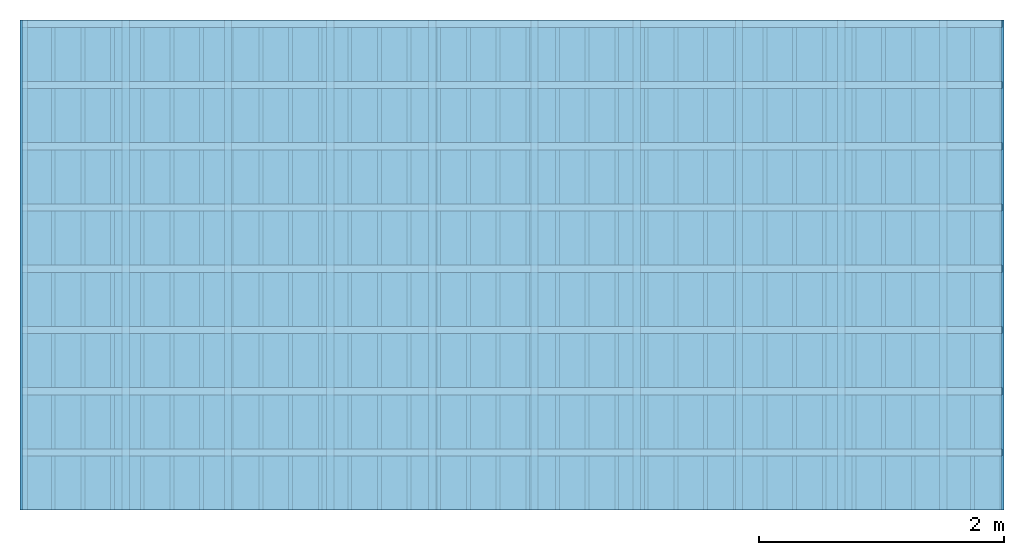
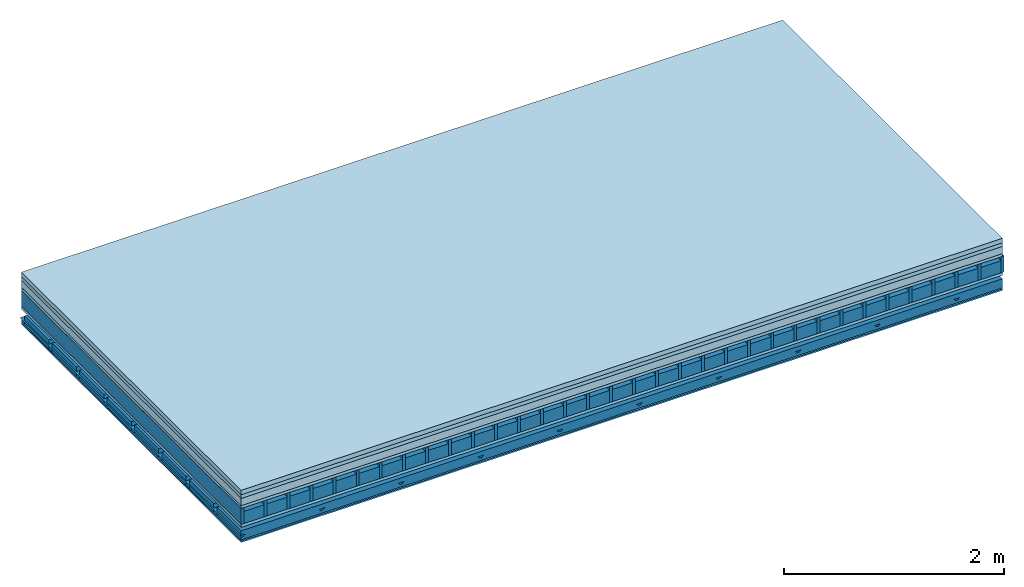
# One storey: 7 plates, 5 members, 1 element without a shape of its own.
"""IFC4 building model written with IfcOpenShell, lengths in metres."""

from ifc_helpers import new_model, si_unit, derived_unit, direction, frame, frame_2d, origin, origin_with_axes, place, context, project, spatial, polyline, rectangle, outline, extrude, material, layer, layer_set, type_object, element, aggregate, save


model = new_model("IFC4")

# Units and contexts
plan_context = context("Plan", 3, precision=1e-05, world=origin(), true_north=direction((0.0, 1.0)))
model_context = context("Model", 3, precision=1e-05, world=origin(), true_north=direction((0.0, 1.0)))
ifc_project = project(units=[si_unit("LENGTHUNIT", "METRE"), derived_unit("SOUNDPRESSUREUNIT", [(si_unit("PRESSUREUNIT", "PASCAL", prefix="MICRO"), 0)]), si_unit("ENERGYUNIT", "JOULE", prefix="MEGA"), si_unit("MASSUNIT", "GRAM", prefix="KILO"), derived_unit("THERMALTRANSMITTANCEUNIT", [(si_unit("POWERUNIT", "WATT"), 1), (si_unit("AREAUNIT", "SQUARE_METRE"), -1), (si_unit("THERMODYNAMICTEMPERATUREUNIT", "KELVIN"), -1)]), derived_unit("AREADENSITYUNIT", [(si_unit("MASSUNIT", "GRAM", prefix="KILO"), 1), (si_unit("AREAUNIT", "SQUARE_METRE"), -1)]), derived_unit("USERDEFINED", [(si_unit("ENERGYUNIT", "JOULE", prefix="MEGA"), 1), (si_unit("AREAUNIT", "SQUARE_METRE"), -1)])], contexts=[plan_context, model_context])

# Site, building, storey
site = spatial("IfcSite", under=ifc_project)
building_placement = place(None, origin())
building = spatial("IfcBuilding", under=site, at=building_placement)
storey_placement = place(building_placement, origin())
storey = spatial("IfcBuildingStorey", under=building, at=storey_placement)

# Slab, members, plates
ifc_material_1 = material(Category="04.005")
ifc_layer_1 = layer(ifc_material_1, 0.05, Name="On-material")
ifc_material_2 = material(Name="EP1, 40/35mm")
ifc_layer_2 = layer(ifc_material_2, 0.04, Name="Impact sound insulation")
ifc_material_3 = material(Category="03.011")
ifc_layer_3 = layer(ifc_material_3, 0.08, Name="on Supporting structure")
ifc_material_4 = material(Name="surface element sheathing above")
ifc_layer_4 = layer(ifc_material_4, 0.031, Name="Sub-floor")
ifc_layer_5 = layer(None, 0.178, Name="Supporting structure")
ifc_material_5 = material(Name="surface element sheathing below")
ifc_layer_6 = layer(ifc_material_5, 0.031, Name="Lower layer 1")
ifc_layer_7 = layer(None, 0.11, Name="Coupling")
ifc_layer_8 = layer(None, 0.03, Name="Battens / profiles")
ifc_material_6 = material(Name="Plasterboard type A", Category="03.008")
ifc_layer_9 = layer(ifc_material_6, 0.015, Name="Ceiling covering 1st layer")
ifc_layer_10 = layer(ifc_material_6, 0.015, Name="Ceiling covering layer 2")
ifc_material_7 = material(Name="joints", Category="04.017")
ifc_layer_11 = layer(ifc_material_7, 0.0, Name="Surface / treatment")
ifc_layer_set = layer_set([ifc_layer_1, ifc_layer_2, ifc_layer_3, ifc_layer_4, ifc_layer_5, ifc_layer_6, ifc_layer_7, ifc_layer_8, ifc_layer_9, ifc_layer_10, ifc_layer_11])
slab_type = type_object("IfcSlabType", Name="A1469", PredefinedType="NOTDEFINED", material=ifc_layer_set)
slab_placement = place(None, frame((0.0, 0.0, 0.0), z_axis=(0.0, 0.0, -1.0), x_axis=(1.0, 0.0, 0.0)))
slab = element("IfcSlab", 1, at=slab_placement, inside=storey, type_object=slab_type, material=ifc_layer_set, Name="Slab #1")
ifc_material_8 = material(Name="surface element LFE 12")
member_1_placement = place(slab_placement, origin())
member_1 = element("IfcMember", 2, at=member_1_placement, material=ifc_material_8, Name="Supporting structure", context=plan_context, shape_type="SweptSolid", body=[
    extrude(rectangle(XDim=0.031, YDim=0.178, at=frame_2d((0.0155, 0.089), x_axis=(1.0, 0.0))), frame((0.0, 4.0, 0.201), z_axis=(0.0, -1.0, 0.0), x_axis=(1.0, 0.0, 0.0)), (0.0, 0.0, 1.0), 4.0),
    extrude(rectangle(XDim=0.031, YDim=0.178, at=frame_2d((0.0155, 0.089), x_axis=(1.0, 0.0))), frame((0.242, 4.0, 0.201), z_axis=(0.0, -1.0, 0.0), x_axis=(1.0, 0.0, 0.0)), (0.0, 0.0, 1.0), 4.0),
    extrude(rectangle(XDim=0.031, YDim=0.178, at=frame_2d((0.0155, 0.089), x_axis=(1.0, 0.0))), frame((0.484, 4.0, 0.201), z_axis=(0.0, -1.0, 0.0), x_axis=(1.0, 0.0, 0.0)), (0.0, 0.0, 1.0), 4.0),
    extrude(rectangle(XDim=0.031, YDim=0.178, at=frame_2d((0.0155, 0.089), x_axis=(1.0, 0.0))), frame((0.726, 4.0, 0.201), z_axis=(0.0, -1.0, 0.0), x_axis=(1.0, 0.0, 0.0)), (0.0, 0.0, 1.0), 4.0),
    extrude(rectangle(XDim=0.031, YDim=0.178, at=frame_2d((0.0155, 0.089), x_axis=(1.0, 0.0))), frame((0.968, 4.0, 0.201), z_axis=(0.0, -1.0, 0.0), x_axis=(1.0, 0.0, 0.0)), (0.0, 0.0, 1.0), 4.0),
    extrude(rectangle(XDim=0.031, YDim=0.178, at=frame_2d((0.0155, 0.089), x_axis=(1.0, 0.0))), frame((1.21, 4.0, 0.201), z_axis=(0.0, -1.0, 0.0), x_axis=(1.0, 0.0, 0.0)), (0.0, 0.0, 1.0), 4.0),
    extrude(rectangle(XDim=0.031, YDim=0.178, at=frame_2d((0.0155, 0.089), x_axis=(1.0, 0.0))), frame((1.452, 4.0, 0.201), z_axis=(0.0, -1.0, 0.0), x_axis=(1.0, 0.0, 0.0)), (0.0, 0.0, 1.0), 4.0),
    extrude(rectangle(XDim=0.031, YDim=0.178, at=frame_2d((0.0155, 0.089), x_axis=(1.0, 0.0))), frame((1.694, 4.0, 0.201), z_axis=(0.0, -1.0, 0.0), x_axis=(1.0, 0.0, 0.0)), (0.0, 0.0, 1.0), 4.0),
    extrude(rectangle(XDim=0.031, YDim=0.178, at=frame_2d((0.0155, 0.089), x_axis=(1.0, 0.0))), frame((1.936, 4.0, 0.201), z_axis=(0.0, -1.0, 0.0), x_axis=(1.0, 0.0, 0.0)), (0.0, 0.0, 1.0), 4.0),
    extrude(rectangle(XDim=0.031, YDim=0.178, at=frame_2d((0.0155, 0.089), x_axis=(1.0, 0.0))), frame((2.178, 4.0, 0.201), z_axis=(0.0, -1.0, 0.0), x_axis=(1.0, 0.0, 0.0)), (0.0, 0.0, 1.0), 4.0),
    extrude(rectangle(XDim=0.031, YDim=0.178, at=frame_2d((0.0155, 0.089), x_axis=(1.0, 0.0))), frame((2.42, 4.0, 0.201), z_axis=(0.0, -1.0, 0.0), x_axis=(1.0, 0.0, 0.0)), (0.0, 0.0, 1.0), 4.0),
    extrude(rectangle(XDim=0.031, YDim=0.178, at=frame_2d((0.0155, 0.089), x_axis=(1.0, 0.0))), frame((2.662, 4.0, 0.201), z_axis=(0.0, -1.0, 0.0), x_axis=(1.0, 0.0, 0.0)), (0.0, 0.0, 1.0), 4.0),
    extrude(rectangle(XDim=0.031, YDim=0.178, at=frame_2d((0.0155, 0.089), x_axis=(1.0, 0.0))), frame((2.904, 4.0, 0.201), z_axis=(0.0, -1.0, 0.0), x_axis=(1.0, 0.0, 0.0)), (0.0, 0.0, 1.0), 4.0),
    extrude(rectangle(XDim=0.031, YDim=0.178, at=frame_2d((0.0155, 0.089), x_axis=(1.0, 0.0))), frame((3.146, 4.0, 0.201), z_axis=(0.0, -1.0, 0.0), x_axis=(1.0, 0.0, 0.0)), (0.0, 0.0, 1.0), 4.0),
    extrude(rectangle(XDim=0.031, YDim=0.178, at=frame_2d((0.0155, 0.089), x_axis=(1.0, 0.0))), frame((3.388, 4.0, 0.201), z_axis=(0.0, -1.0, 0.0), x_axis=(1.0, 0.0, 0.0)), (0.0, 0.0, 1.0), 4.0),
    extrude(rectangle(XDim=0.031, YDim=0.178, at=frame_2d((0.0155, 0.089), x_axis=(1.0, 0.0))), frame((3.63, 4.0, 0.201), z_axis=(0.0, -1.0, 0.0), x_axis=(1.0, 0.0, 0.0)), (0.0, 0.0, 1.0), 4.0),
    extrude(rectangle(XDim=0.031, YDim=0.178, at=frame_2d((0.0155, 0.089), x_axis=(1.0, 0.0))), frame((3.872, 4.0, 0.201), z_axis=(0.0, -1.0, 0.0), x_axis=(1.0, 0.0, 0.0)), (0.0, 0.0, 1.0), 4.0),
    extrude(rectangle(XDim=0.031, YDim=0.178, at=frame_2d((0.0155, 0.089), x_axis=(1.0, 0.0))), frame((4.114, 4.0, 0.201), z_axis=(0.0, -1.0, 0.0), x_axis=(1.0, 0.0, 0.0)), (0.0, 0.0, 1.0), 4.0),
    extrude(rectangle(XDim=0.031, YDim=0.178, at=frame_2d((0.0155, 0.089), x_axis=(1.0, 0.0))), frame((4.356, 4.0, 0.201), z_axis=(0.0, -1.0, 0.0), x_axis=(1.0, 0.0, 0.0)), (0.0, 0.0, 1.0), 4.0),
    extrude(rectangle(XDim=0.031, YDim=0.178, at=frame_2d((0.0155, 0.089), x_axis=(1.0, 0.0))), frame((4.598, 4.0, 0.201), z_axis=(0.0, -1.0, 0.0), x_axis=(1.0, 0.0, 0.0)), (0.0, 0.0, 1.0), 4.0),
    extrude(rectangle(XDim=0.031, YDim=0.178, at=frame_2d((0.0155, 0.089), x_axis=(1.0, 0.0))), frame((4.84, 4.0, 0.201), z_axis=(0.0, -1.0, 0.0), x_axis=(1.0, 0.0, 0.0)), (0.0, 0.0, 1.0), 4.0),
    extrude(rectangle(XDim=0.031, YDim=0.178, at=frame_2d((0.0155, 0.089), x_axis=(1.0, 0.0))), frame((5.082, 4.0, 0.201), z_axis=(0.0, -1.0, 0.0), x_axis=(1.0, 0.0, 0.0)), (0.0, 0.0, 1.0), 4.0),
    extrude(rectangle(XDim=0.031, YDim=0.178, at=frame_2d((0.0155, 0.089), x_axis=(1.0, 0.0))), frame((5.324, 4.0, 0.201), z_axis=(0.0, -1.0, 0.0), x_axis=(1.0, 0.0, 0.0)), (0.0, 0.0, 1.0), 4.0),
    extrude(rectangle(XDim=0.031, YDim=0.178, at=frame_2d((0.0155, 0.089), x_axis=(1.0, 0.0))), frame((5.566, 4.0, 0.201), z_axis=(0.0, -1.0, 0.0), x_axis=(1.0, 0.0, 0.0)), (0.0, 0.0, 1.0), 4.0),
    extrude(rectangle(XDim=0.031, YDim=0.178, at=frame_2d((0.0155, 0.089), x_axis=(1.0, 0.0))), frame((5.808, 4.0, 0.201), z_axis=(0.0, -1.0, 0.0), x_axis=(1.0, 0.0, 0.0)), (0.0, 0.0, 1.0), 4.0),
    extrude(rectangle(XDim=0.031, YDim=0.178, at=frame_2d((0.0155, 0.089), x_axis=(1.0, 0.0))), frame((6.05, 4.0, 0.201), z_axis=(0.0, -1.0, 0.0), x_axis=(1.0, 0.0, 0.0)), (0.0, 0.0, 1.0), 4.0),
    extrude(rectangle(XDim=0.031, YDim=0.178, at=frame_2d((0.0155, 0.089), x_axis=(1.0, 0.0))), frame((6.292, 4.0, 0.201), z_axis=(0.0, -1.0, 0.0), x_axis=(1.0, 0.0, 0.0)), (0.0, 0.0, 1.0), 4.0),
    extrude(rectangle(XDim=0.031, YDim=0.178, at=frame_2d((0.0155, 0.089), x_axis=(1.0, 0.0))), frame((6.534, 4.0, 0.201), z_axis=(0.0, -1.0, 0.0), x_axis=(1.0, 0.0, 0.0)), (0.0, 0.0, 1.0), 4.0),
    extrude(rectangle(XDim=0.031, YDim=0.178, at=frame_2d((0.0155, 0.089), x_axis=(1.0, 0.0))), frame((6.776, 4.0, 0.201), z_axis=(0.0, -1.0, 0.0), x_axis=(1.0, 0.0, 0.0)), (0.0, 0.0, 1.0), 4.0),
    extrude(rectangle(XDim=0.031, YDim=0.178, at=frame_2d((0.0155, 0.089), x_axis=(1.0, 0.0))), frame((7.018, 4.0, 0.201), z_axis=(0.0, -1.0, 0.0), x_axis=(1.0, 0.0, 0.0)), (0.0, 0.0, 1.0), 4.0),
    extrude(rectangle(XDim=0.031, YDim=0.178, at=frame_2d((0.0155, 0.089), x_axis=(1.0, 0.0))), frame((7.26, 4.0, 0.201), z_axis=(0.0, -1.0, 0.0), x_axis=(1.0, 0.0, 0.0)), (0.0, 0.0, 1.0), 4.0),
    extrude(rectangle(XDim=0.031, YDim=0.178, at=frame_2d((0.0155, 0.089), x_axis=(1.0, 0.0))), frame((7.502, 4.0, 0.201), z_axis=(0.0, -1.0, 0.0), x_axis=(1.0, 0.0, 0.0)), (0.0, 0.0, 1.0), 4.0),
    extrude(rectangle(XDim=0.031, YDim=0.178, at=frame_2d((0.0155, 0.089), x_axis=(1.0, 0.0))), frame((7.744, 4.0, 0.201), z_axis=(0.0, -1.0, 0.0), x_axis=(1.0, 0.0, 0.0)), (0.0, 0.0, 1.0), 4.0),
    extrude(rectangle(XDim=0.031, YDim=0.178, at=frame_2d((0.0155, 0.089), x_axis=(1.0, 0.0))), frame((7.986, 4.0, 0.201), z_axis=(0.0, -1.0, 0.0), x_axis=(1.0, 0.0, 0.0)), (0.0, 0.0, 1.0), 4.0),
])
ifc_material_9 = material(Name="Damper LFE 12")
member_2_placement = place(slab_placement, origin())
member_2 = element("IfcMember", 3, at=member_2_placement, material=ifc_material_9, Name="in supporting structure", context=plan_context, shape_type="SweptSolid", body=[
    extrude(rectangle(XDim=0.211, YDim=0.135, at=frame_2d((0.1055, 0.0675), x_axis=(1.0, 0.0))), frame((0.031, 4.0, 0.244), z_axis=(0.0, -1.0, 0.0), x_axis=(1.0, 0.0, 0.0)), (0.0, 0.0, 1.0), 4.0),
    extrude(rectangle(XDim=0.211, YDim=0.135, at=frame_2d((0.1055, 0.0675), x_axis=(1.0, 0.0))), frame((0.273, 4.0, 0.244), z_axis=(0.0, -1.0, 0.0), x_axis=(1.0, 0.0, 0.0)), (0.0, 0.0, 1.0), 4.0),
    extrude(rectangle(XDim=0.211, YDim=0.135, at=frame_2d((0.1055, 0.0675), x_axis=(1.0, 0.0))), frame((0.515, 4.0, 0.244), z_axis=(0.0, -1.0, 0.0), x_axis=(1.0, 0.0, 0.0)), (0.0, 0.0, 1.0), 4.0),
    extrude(rectangle(XDim=0.211, YDim=0.135, at=frame_2d((0.1055, 0.0675), x_axis=(1.0, 0.0))), frame((0.757, 4.0, 0.244), z_axis=(0.0, -1.0, 0.0), x_axis=(1.0, 0.0, 0.0)), (0.0, 0.0, 1.0), 4.0),
    extrude(rectangle(XDim=0.211, YDim=0.135, at=frame_2d((0.1055, 0.0675), x_axis=(1.0, 0.0))), frame((0.999, 4.0, 0.244), z_axis=(0.0, -1.0, 0.0), x_axis=(1.0, 0.0, 0.0)), (0.0, 0.0, 1.0), 4.0),
    extrude(rectangle(XDim=0.211, YDim=0.135, at=frame_2d((0.1055, 0.0675), x_axis=(1.0, 0.0))), frame((1.241, 4.0, 0.244), z_axis=(0.0, -1.0, 0.0), x_axis=(1.0, 0.0, 0.0)), (0.0, 0.0, 1.0), 4.0),
    extrude(rectangle(XDim=0.211, YDim=0.135, at=frame_2d((0.1055, 0.0675), x_axis=(1.0, 0.0))), frame((1.483, 4.0, 0.244), z_axis=(0.0, -1.0, 0.0), x_axis=(1.0, 0.0, 0.0)), (0.0, 0.0, 1.0), 4.0),
    extrude(rectangle(XDim=0.211, YDim=0.135, at=frame_2d((0.1055, 0.0675), x_axis=(1.0, 0.0))), frame((1.725, 4.0, 0.244), z_axis=(0.0, -1.0, 0.0), x_axis=(1.0, 0.0, 0.0)), (0.0, 0.0, 1.0), 4.0),
    extrude(rectangle(XDim=0.211, YDim=0.135, at=frame_2d((0.1055, 0.0675), x_axis=(1.0, 0.0))), frame((1.967, 4.0, 0.244), z_axis=(0.0, -1.0, 0.0), x_axis=(1.0, 0.0, 0.0)), (0.0, 0.0, 1.0), 4.0),
    extrude(rectangle(XDim=0.211, YDim=0.135, at=frame_2d((0.1055, 0.0675), x_axis=(1.0, 0.0))), frame((2.209, 4.0, 0.244), z_axis=(0.0, -1.0, 0.0), x_axis=(1.0, 0.0, 0.0)), (0.0, 0.0, 1.0), 4.0),
    extrude(rectangle(XDim=0.211, YDim=0.135, at=frame_2d((0.1055, 0.0675), x_axis=(1.0, 0.0))), frame((2.451, 4.0, 0.244), z_axis=(0.0, -1.0, 0.0), x_axis=(1.0, 0.0, 0.0)), (0.0, 0.0, 1.0), 4.0),
    extrude(rectangle(XDim=0.211, YDim=0.135, at=frame_2d((0.1055, 0.0675), x_axis=(1.0, 0.0))), frame((2.693, 4.0, 0.244), z_axis=(0.0, -1.0, 0.0), x_axis=(1.0, 0.0, 0.0)), (0.0, 0.0, 1.0), 4.0),
    extrude(rectangle(XDim=0.211, YDim=0.135, at=frame_2d((0.1055, 0.0675), x_axis=(1.0, 0.0))), frame((2.935, 4.0, 0.244), z_axis=(0.0, -1.0, 0.0), x_axis=(1.0, 0.0, 0.0)), (0.0, 0.0, 1.0), 4.0),
    extrude(rectangle(XDim=0.211, YDim=0.135, at=frame_2d((0.1055, 0.0675), x_axis=(1.0, 0.0))), frame((3.177, 4.0, 0.244), z_axis=(0.0, -1.0, 0.0), x_axis=(1.0, 0.0, 0.0)), (0.0, 0.0, 1.0), 4.0),
    extrude(rectangle(XDim=0.211, YDim=0.135, at=frame_2d((0.1055, 0.0675), x_axis=(1.0, 0.0))), frame((3.419, 4.0, 0.244), z_axis=(0.0, -1.0, 0.0), x_axis=(1.0, 0.0, 0.0)), (0.0, 0.0, 1.0), 4.0),
    extrude(rectangle(XDim=0.211, YDim=0.135, at=frame_2d((0.1055, 0.0675), x_axis=(1.0, 0.0))), frame((3.661, 4.0, 0.244), z_axis=(0.0, -1.0, 0.0), x_axis=(1.0, 0.0, 0.0)), (0.0, 0.0, 1.0), 4.0),
    extrude(rectangle(XDim=0.211, YDim=0.135, at=frame_2d((0.1055, 0.0675), x_axis=(1.0, 0.0))), frame((3.903, 4.0, 0.244), z_axis=(0.0, -1.0, 0.0), x_axis=(1.0, 0.0, 0.0)), (0.0, 0.0, 1.0), 4.0),
    extrude(rectangle(XDim=0.211, YDim=0.135, at=frame_2d((0.1055, 0.0675), x_axis=(1.0, 0.0))), frame((4.145, 4.0, 0.244), z_axis=(0.0, -1.0, 0.0), x_axis=(1.0, 0.0, 0.0)), (0.0, 0.0, 1.0), 4.0),
    extrude(rectangle(XDim=0.211, YDim=0.135, at=frame_2d((0.1055, 0.0675), x_axis=(1.0, 0.0))), frame((4.387, 4.0, 0.244), z_axis=(0.0, -1.0, 0.0), x_axis=(1.0, 0.0, 0.0)), (0.0, 0.0, 1.0), 4.0),
    extrude(rectangle(XDim=0.211, YDim=0.135, at=frame_2d((0.1055, 0.0675), x_axis=(1.0, 0.0))), frame((4.629, 4.0, 0.244), z_axis=(0.0, -1.0, 0.0), x_axis=(1.0, 0.0, 0.0)), (0.0, 0.0, 1.0), 4.0),
    extrude(rectangle(XDim=0.211, YDim=0.135, at=frame_2d((0.1055, 0.0675), x_axis=(1.0, 0.0))), frame((4.871, 4.0, 0.244), z_axis=(0.0, -1.0, 0.0), x_axis=(1.0, 0.0, 0.0)), (0.0, 0.0, 1.0), 4.0),
    extrude(rectangle(XDim=0.211, YDim=0.135, at=frame_2d((0.1055, 0.0675), x_axis=(1.0, 0.0))), frame((5.113, 4.0, 0.244), z_axis=(0.0, -1.0, 0.0), x_axis=(1.0, 0.0, 0.0)), (0.0, 0.0, 1.0), 4.0),
    extrude(rectangle(XDim=0.211, YDim=0.135, at=frame_2d((0.1055, 0.0675), x_axis=(1.0, 0.0))), frame((5.355, 4.0, 0.244), z_axis=(0.0, -1.0, 0.0), x_axis=(1.0, 0.0, 0.0)), (0.0, 0.0, 1.0), 4.0),
    extrude(rectangle(XDim=0.211, YDim=0.135, at=frame_2d((0.1055, 0.0675), x_axis=(1.0, 0.0))), frame((5.597, 4.0, 0.244), z_axis=(0.0, -1.0, 0.0), x_axis=(1.0, 0.0, 0.0)), (0.0, 0.0, 1.0), 4.0),
    extrude(rectangle(XDim=0.211, YDim=0.135, at=frame_2d((0.1055, 0.0675), x_axis=(1.0, 0.0))), frame((5.839, 4.0, 0.244), z_axis=(0.0, -1.0, 0.0), x_axis=(1.0, 0.0, 0.0)), (0.0, 0.0, 1.0), 4.0),
    extrude(rectangle(XDim=0.211, YDim=0.135, at=frame_2d((0.1055, 0.0675), x_axis=(1.0, 0.0))), frame((6.081, 4.0, 0.244), z_axis=(0.0, -1.0, 0.0), x_axis=(1.0, 0.0, 0.0)), (0.0, 0.0, 1.0), 4.0),
    extrude(rectangle(XDim=0.211, YDim=0.135, at=frame_2d((0.1055, 0.0675), x_axis=(1.0, 0.0))), frame((6.323, 4.0, 0.244), z_axis=(0.0, -1.0, 0.0), x_axis=(1.0, 0.0, 0.0)), (0.0, 0.0, 1.0), 4.0),
    extrude(rectangle(XDim=0.211, YDim=0.135, at=frame_2d((0.1055, 0.0675), x_axis=(1.0, 0.0))), frame((6.565, 4.0, 0.244), z_axis=(0.0, -1.0, 0.0), x_axis=(1.0, 0.0, 0.0)), (0.0, 0.0, 1.0), 4.0),
    extrude(rectangle(XDim=0.211, YDim=0.135, at=frame_2d((0.1055, 0.0675), x_axis=(1.0, 0.0))), frame((6.807, 4.0, 0.244), z_axis=(0.0, -1.0, 0.0), x_axis=(1.0, 0.0, 0.0)), (0.0, 0.0, 1.0), 4.0),
    extrude(rectangle(XDim=0.211, YDim=0.135, at=frame_2d((0.1055, 0.0675), x_axis=(1.0, 0.0))), frame((7.049, 4.0, 0.244), z_axis=(0.0, -1.0, 0.0), x_axis=(1.0, 0.0, 0.0)), (0.0, 0.0, 1.0), 4.0),
    extrude(rectangle(XDim=0.211, YDim=0.135, at=frame_2d((0.1055, 0.0675), x_axis=(1.0, 0.0))), frame((7.291, 4.0, 0.244), z_axis=(0.0, -1.0, 0.0), x_axis=(1.0, 0.0, 0.0)), (0.0, 0.0, 1.0), 4.0),
    extrude(rectangle(XDim=0.211, YDim=0.135, at=frame_2d((0.1055, 0.0675), x_axis=(1.0, 0.0))), frame((7.533, 4.0, 0.244), z_axis=(0.0, -1.0, 0.0), x_axis=(1.0, 0.0, 0.0)), (0.0, 0.0, 1.0), 4.0),
    extrude(rectangle(XDim=0.211, YDim=0.135, at=frame_2d((0.1055, 0.0675), x_axis=(1.0, 0.0))), frame((7.775, 4.0, 0.244), z_axis=(0.0, -1.0, 0.0), x_axis=(1.0, 0.0, 0.0)), (0.0, 0.0, 1.0), 4.0),
])
ifc_material_10 = material()
member_3_placement = place(slab_placement, origin())
member_3 = element("IfcMember", 4, at=member_3_placement, material=ifc_material_10, Name="Coupling", context=plan_context, shape_type="SweptSolid", body=[
    extrude(outline(polyline([(0.0, 0.0), (0.06, 0.0), (0.04, 0.02), (0.02, 0.02), (0.0, 0.0)])), frame((-0.0145, 4.0, 0.5), z_axis=(0.0, -1.0, 0.0), x_axis=(1.0, 0.0, 0.0)), (0.0, 0.0, 1.0), 4.0),
    extrude(outline(polyline([(0.0, 0.0), (0.06, 0.0), (0.04, 0.02), (0.02, 0.02), (0.0, 0.0)])), frame((0.8195, 4.0, 0.5), z_axis=(0.0, -1.0, 0.0), x_axis=(1.0, 0.0, 0.0)), (0.0, 0.0, 1.0), 4.0),
    extrude(outline(polyline([(0.0, 0.0), (0.06, 0.0), (0.04, 0.02), (0.02, 0.02), (0.0, 0.0)])), frame((1.6535, 4.0, 0.5), z_axis=(0.0, -1.0, 0.0), x_axis=(1.0, 0.0, 0.0)), (0.0, 0.0, 1.0), 4.0),
    extrude(outline(polyline([(0.0, 0.0), (0.06, 0.0), (0.04, 0.02), (0.02, 0.02), (0.0, 0.0)])), frame((2.4875, 4.0, 0.5), z_axis=(0.0, -1.0, 0.0), x_axis=(1.0, 0.0, 0.0)), (0.0, 0.0, 1.0), 4.0),
    extrude(outline(polyline([(0.0, 0.0), (0.06, 0.0), (0.04, 0.02), (0.02, 0.02), (0.0, 0.0)])), frame((3.3215, 4.0, 0.5), z_axis=(0.0, -1.0, 0.0), x_axis=(1.0, 0.0, 0.0)), (0.0, 0.0, 1.0), 4.0),
    extrude(outline(polyline([(0.0, 0.0), (0.06, 0.0), (0.04, 0.02), (0.02, 0.02), (0.0, 0.0)])), frame((4.1555, 4.0, 0.5), z_axis=(0.0, -1.0, 0.0), x_axis=(1.0, 0.0, 0.0)), (0.0, 0.0, 1.0), 4.0),
    extrude(outline(polyline([(0.0, 0.0), (0.06, 0.0), (0.04, 0.02), (0.02, 0.02), (0.0, 0.0)])), frame((4.9895, 4.0, 0.5), z_axis=(0.0, -1.0, 0.0), x_axis=(1.0, 0.0, 0.0)), (0.0, 0.0, 1.0), 4.0),
    extrude(outline(polyline([(0.0, 0.0), (0.06, 0.0), (0.04, 0.02), (0.02, 0.02), (0.0, 0.0)])), frame((5.8235, 4.0, 0.5), z_axis=(0.0, -1.0, 0.0), x_axis=(1.0, 0.0, 0.0)), (0.0, 0.0, 1.0), 4.0),
    extrude(outline(polyline([(0.0, 0.0), (0.06, 0.0), (0.04, 0.02), (0.02, 0.02), (0.0, 0.0)])), frame((6.6575, 4.0, 0.5), z_axis=(0.0, -1.0, 0.0), x_axis=(1.0, 0.0, 0.0)), (0.0, 0.0, 1.0), 4.0),
    extrude(outline(polyline([(0.0, 0.0), (0.06, 0.0), (0.04, 0.02), (0.02, 0.02), (0.0, 0.0)])), frame((7.4915, 4.0, 0.5), z_axis=(0.0, -1.0, 0.0), x_axis=(1.0, 0.0, 0.0)), (0.0, 0.0, 1.0), 4.0),
])
ifc_material_11 = material()
member_4_placement = place(slab_placement, origin())
member_4 = element("IfcMember", 5, at=member_4_placement, material=ifc_material_11, Name="Battens / profiles", context=plan_context, shape_type="SweptSolid", body=[
    extrude(rectangle(XDim=0.06, YDim=0.03, at=frame_2d((0.03, 0.015), x_axis=(1.0, 0.0))), frame((0.0, 0.0, 0.52), z_axis=(1.0, 0.0, 0.0), x_axis=(0.0, 1.0, 0.0)), (0.0, 0.0, 1.0), 8.0),
    extrude(rectangle(XDim=0.06, YDim=0.03, at=frame_2d((0.03, 0.015), x_axis=(1.0, 0.0))), frame((0.0, 0.5, 0.52), z_axis=(1.0, 0.0, 0.0), x_axis=(0.0, 1.0, 0.0)), (0.0, 0.0, 1.0), 8.0),
    extrude(rectangle(XDim=0.06, YDim=0.03, at=frame_2d((0.03, 0.015), x_axis=(1.0, 0.0))), frame((0.0, 1.0, 0.52), z_axis=(1.0, 0.0, 0.0), x_axis=(0.0, 1.0, 0.0)), (0.0, 0.0, 1.0), 8.0),
    extrude(rectangle(XDim=0.06, YDim=0.03, at=frame_2d((0.03, 0.015), x_axis=(1.0, 0.0))), frame((0.0, 1.5, 0.52), z_axis=(1.0, 0.0, 0.0), x_axis=(0.0, 1.0, 0.0)), (0.0, 0.0, 1.0), 8.0),
    extrude(rectangle(XDim=0.06, YDim=0.03, at=frame_2d((0.03, 0.015), x_axis=(1.0, 0.0))), frame((0.0, 2.0, 0.52), z_axis=(1.0, 0.0, 0.0), x_axis=(0.0, 1.0, 0.0)), (0.0, 0.0, 1.0), 8.0),
    extrude(rectangle(XDim=0.06, YDim=0.03, at=frame_2d((0.03, 0.015), x_axis=(1.0, 0.0))), frame((0.0, 2.5, 0.52), z_axis=(1.0, 0.0, 0.0), x_axis=(0.0, 1.0, 0.0)), (0.0, 0.0, 1.0), 8.0),
    extrude(rectangle(XDim=0.06, YDim=0.03, at=frame_2d((0.03, 0.015), x_axis=(1.0, 0.0))), frame((0.0, 3.0, 0.52), z_axis=(1.0, 0.0, 0.0), x_axis=(0.0, 1.0, 0.0)), (0.0, 0.0, 1.0), 8.0),
    extrude(rectangle(XDim=0.06, YDim=0.03, at=frame_2d((0.03, 0.015), x_axis=(1.0, 0.0))), frame((0.0, 3.5, 0.52), z_axis=(1.0, 0.0, 0.0), x_axis=(0.0, 1.0, 0.0)), (0.0, 0.0, 1.0), 8.0),
])
ifc_material_12 = material()
member_5_placement = place(slab_placement, origin())
member_5 = element("IfcMember", 6, at=member_5_placement, material=ifc_material_12, Name="Cavity", context=plan_context, shape_type="SweptSolid", body=[
    extrude(rectangle(XDim=0.44, YDim=0.1, at=frame_2d((0.22, 0.05), x_axis=(1.0, 0.0))), frame((0.0, 0.06, 0.45), z_axis=(1.0, 0.0, 0.0), x_axis=(0.0, 1.0, 0.0)), (0.0, 0.0, 1.0), 8.0),
    extrude(rectangle(XDim=0.44, YDim=0.1, at=frame_2d((0.22, 0.05), x_axis=(1.0, 0.0))), frame((0.0, 0.56, 0.45), z_axis=(1.0, 0.0, 0.0), x_axis=(0.0, 1.0, 0.0)), (0.0, 0.0, 1.0), 8.0),
    extrude(rectangle(XDim=0.44, YDim=0.1, at=frame_2d((0.22, 0.05), x_axis=(1.0, 0.0))), frame((0.0, 1.06, 0.45), z_axis=(1.0, 0.0, 0.0), x_axis=(0.0, 1.0, 0.0)), (0.0, 0.0, 1.0), 8.0),
    extrude(rectangle(XDim=0.44, YDim=0.1, at=frame_2d((0.22, 0.05), x_axis=(1.0, 0.0))), frame((0.0, 1.56, 0.45), z_axis=(1.0, 0.0, 0.0), x_axis=(0.0, 1.0, 0.0)), (0.0, 0.0, 1.0), 8.0),
    extrude(rectangle(XDim=0.44, YDim=0.1, at=frame_2d((0.22, 0.05), x_axis=(1.0, 0.0))), frame((0.0, 2.06, 0.45), z_axis=(1.0, 0.0, 0.0), x_axis=(0.0, 1.0, 0.0)), (0.0, 0.0, 1.0), 8.0),
    extrude(rectangle(XDim=0.44, YDim=0.1, at=frame_2d((0.22, 0.05), x_axis=(1.0, 0.0))), frame((0.0, 2.56, 0.45), z_axis=(1.0, 0.0, 0.0), x_axis=(0.0, 1.0, 0.0)), (0.0, 0.0, 1.0), 8.0),
    extrude(rectangle(XDim=0.44, YDim=0.1, at=frame_2d((0.22, 0.05), x_axis=(1.0, 0.0))), frame((0.0, 3.06, 0.45), z_axis=(1.0, 0.0, 0.0), x_axis=(0.0, 1.0, 0.0)), (0.0, 0.0, 1.0), 8.0),
    extrude(rectangle(XDim=0.44, YDim=0.1, at=frame_2d((0.22, 0.05), x_axis=(1.0, 0.0))), frame((0.0, 3.56, 0.45), z_axis=(1.0, 0.0, 0.0), x_axis=(0.0, 1.0, 0.0)), (0.0, 0.0, 1.0), 8.0),
])
plate_1_placement = place(slab_placement, origin())
plate_1 = element("IfcPlate", 7, at=plate_1_placement, material=ifc_material_1, Name="On-material", context=plan_context, shape_type="SweptSolid", body=[
    extrude(rectangle(XDim=8.0, YDim=4.0, at=frame_2d((4.0, 2.0), x_axis=(1.0, 0.0))), origin_with_axes(), (0.0, 0.0, 1.0), 0.05),
])
plate_2_placement = place(slab_placement, origin())
plate_2 = element("IfcPlate", 8, at=plate_2_placement, material=ifc_material_2, Name="Impact sound insulation", context=plan_context, shape_type="SweptSolid", body=[
    extrude(rectangle(XDim=8.0, YDim=4.0, at=frame_2d((4.0, 2.0), x_axis=(1.0, 0.0))), frame((0.0, 0.0, 0.05), z_axis=(0.0, 0.0, 1.0), x_axis=(1.0, 0.0, 0.0)), (0.0, 0.0, 1.0), 0.04),
])
plate_3_placement = place(slab_placement, origin())
plate_3 = element("IfcPlate", 9, at=plate_3_placement, material=ifc_material_3, Name="on Supporting structure", context=plan_context, shape_type="SweptSolid", body=[
    extrude(rectangle(XDim=8.0, YDim=4.0, at=frame_2d((4.0, 2.0), x_axis=(1.0, 0.0))), frame((0.0, 0.0, 0.09), z_axis=(0.0, 0.0, 1.0), x_axis=(1.0, 0.0, 0.0)), (0.0, 0.0, 1.0), 0.08),
])
plate_4_placement = place(slab_placement, origin())
plate_4 = element("IfcPlate", 10, at=plate_4_placement, material=ifc_material_4, Name="Sub-floor", context=plan_context, shape_type="SweptSolid", body=[
    extrude(rectangle(XDim=8.0, YDim=4.0, at=frame_2d((4.0, 2.0), x_axis=(1.0, 0.0))), frame((0.0, 0.0, 0.17), z_axis=(0.0, 0.0, 1.0), x_axis=(1.0, 0.0, 0.0)), (0.0, 0.0, 1.0), 0.031),
])
plate_5_placement = place(slab_placement, origin())
plate_5 = element("IfcPlate", 11, at=plate_5_placement, material=ifc_material_5, Name="Lower layer 1", context=plan_context, shape_type="SweptSolid", body=[
    extrude(rectangle(XDim=8.0, YDim=4.0, at=frame_2d((4.0, 2.0), x_axis=(1.0, 0.0))), frame((0.0, 0.0, 0.379), z_axis=(0.0, 0.0, 1.0), x_axis=(1.0, 0.0, 0.0)), (0.0, 0.0, 1.0), 0.031),
])
plate_6_placement = place(slab_placement, origin())
plate_6 = element("IfcPlate", 12, at=plate_6_placement, material=ifc_material_6, Name="Ceiling covering 1st layer", context=plan_context, shape_type="SweptSolid", body=[
    extrude(rectangle(XDim=8.0, YDim=4.0, at=frame_2d((4.0, 2.0), x_axis=(1.0, 0.0))), frame((0.0, 0.0, 0.55), z_axis=(0.0, 0.0, 1.0), x_axis=(1.0, 0.0, 0.0)), (0.0, 0.0, 1.0), 0.015),
])
plate_7_placement = place(slab_placement, origin())
plate_7 = element("IfcPlate", 13, at=plate_7_placement, material=ifc_material_6, Name="Ceiling covering layer 2", context=plan_context, shape_type="SweptSolid", body=[
    extrude(rectangle(XDim=8.0, YDim=4.0, at=frame_2d((4.0, 2.0), x_axis=(1.0, 0.0))), frame((0.0, 0.0, 0.565), z_axis=(0.0, 0.0, 1.0), x_axis=(1.0, 0.0, 0.0)), (0.0, 0.0, 1.0), 0.015),
])
aggregate(slab, [plate_1, plate_2, plate_3, plate_4, member_1, member_2, plate_5, member_3, member_4, member_5, plate_6, plate_7])

save(model, "model.ifc")
